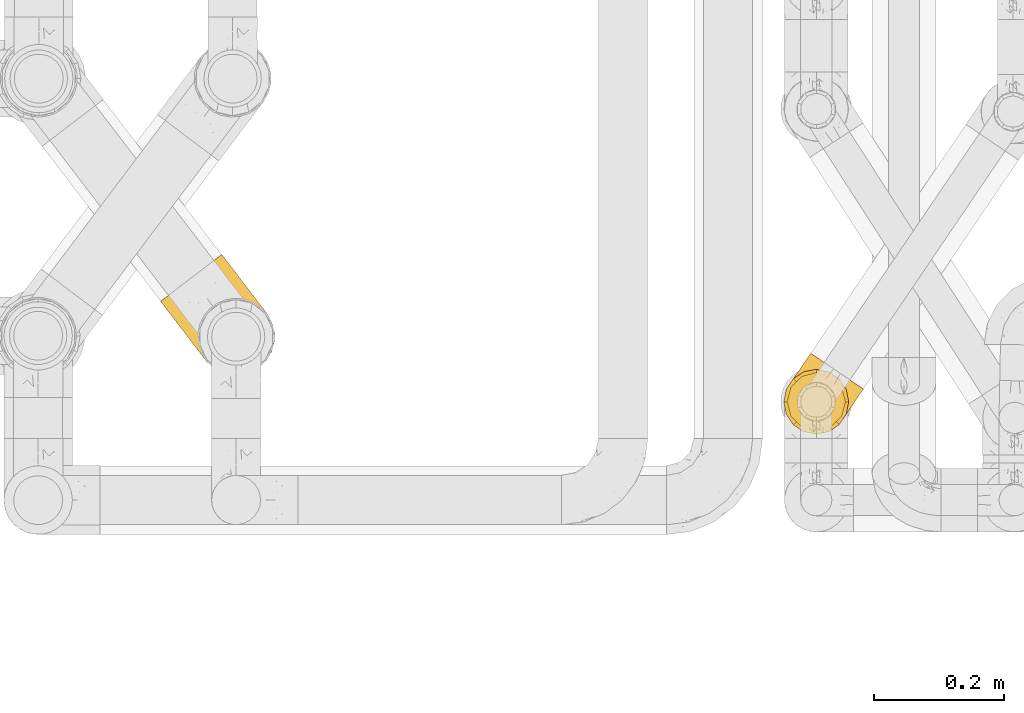
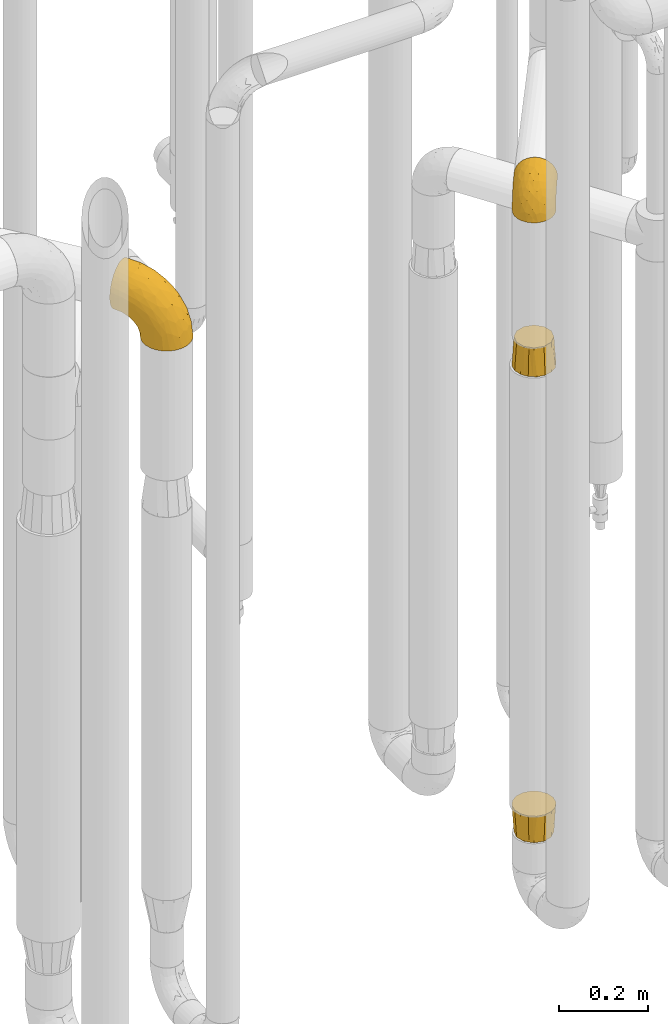
# One storey, part 382 of 827: 4 coverings.
"""IFC2X3 building model written with IfcOpenShell, lengths in millimetres."""

from ifc_helpers import new_model, entity, si_unit, converted_unit, derived_unit, direction, frame, origin, place, context, subcontext, project, spatial, faceted_brep, element, save


model = new_model("IFC2X3")

# Units and contexts
model_context = context("Model", 3, precision=0.01, world=origin(), true_north=direction((6.12303176911189e-17, 1.0)))
body_context = subcontext(model_context, "Body", "Model", "MODEL_VIEW")
ifc_project = project(units=[si_unit("LENGTHUNIT", "METRE", prefix="MILLI"), si_unit("AREAUNIT", "SQUARE_METRE"), si_unit("VOLUMEUNIT", "CUBIC_METRE"), converted_unit("PLANEANGLEUNIT", "DEGREE", entity("IfcRatioMeasure", 0.0174532925199433), si_unit("PLANEANGLEUNIT", "RADIAN"), dimensions=[0, 0, 0, 0, 0, 0, 0]), si_unit("MASSUNIT", "GRAM", prefix="KILO"), derived_unit("MASSDENSITYUNIT", [(si_unit("MASSUNIT", "GRAM", prefix="KILO"), 1), (si_unit("LENGTHUNIT", "METRE"), -3)]), derived_unit("MOMENTOFINERTIAUNIT", [(si_unit("LENGTHUNIT", "METRE"), 4)]), si_unit("TIMEUNIT", "SECOND"), si_unit("FREQUENCYUNIT", "HERTZ"), si_unit("THERMODYNAMICTEMPERATUREUNIT", "DEGREE_CELSIUS"), derived_unit("THERMALTRANSMITTANCEUNIT", [(si_unit("MASSUNIT", "GRAM", prefix="KILO"), 1), (si_unit("THERMODYNAMICTEMPERATUREUNIT", "KELVIN"), -1), (si_unit("TIMEUNIT", "SECOND"), -3)]), derived_unit("VOLUMETRICFLOWRATEUNIT", [(si_unit("LENGTHUNIT", "METRE"), 3), (si_unit("TIMEUNIT", "SECOND"), -1)]), derived_unit("MASSFLOWRATEUNIT", [(si_unit("MASSUNIT", "GRAM", prefix="KILO"), 1), (si_unit("TIMEUNIT", "SECOND"), -1)]), derived_unit("ROTATIONALFREQUENCYUNIT", [(si_unit("TIMEUNIT", "SECOND"), -1)]), si_unit("ELECTRICCURRENTUNIT", "AMPERE"), si_unit("ELECTRICVOLTAGEUNIT", "VOLT"), si_unit("POWERUNIT", "WATT"), si_unit("FORCEUNIT", "NEWTON", prefix="KILO"), si_unit("ILLUMINANCEUNIT", "LUX"), si_unit("LUMINOUSFLUXUNIT", "LUMEN"), si_unit("LUMINOUSINTENSITYUNIT", "CANDELA"), derived_unit("USERDEFINED", [(si_unit("MASSUNIT", "GRAM", prefix="KILO"), -1), (si_unit("LENGTHUNIT", "METRE"), -2), (si_unit("TIMEUNIT", "SECOND"), 3), (si_unit("LUMINOUSFLUXUNIT", "LUMEN"), 1)]), derived_unit("LINEARVELOCITYUNIT", [(si_unit("LENGTHUNIT", "METRE"), 1), (si_unit("TIMEUNIT", "SECOND"), -1)]), si_unit("PRESSUREUNIT", "PASCAL"), derived_unit("USERDEFINED", [(si_unit("LENGTHUNIT", "METRE"), -2), (si_unit("MASSUNIT", "GRAM", prefix="KILO"), 1), (si_unit("TIMEUNIT", "SECOND"), -2)]), derived_unit("LINEARFORCEUNIT", [(si_unit("MASSUNIT", "GRAM", prefix="KILO"), 1), (si_unit("LENGTHUNIT", "METRE"), 1), (si_unit("TIMEUNIT", "SECOND"), -2), (si_unit("LENGTHUNIT", "METRE"), -1)]), derived_unit("PLANARFORCEUNIT", [(si_unit("MASSUNIT", "GRAM", prefix="KILO"), 1), (si_unit("LENGTHUNIT", "METRE"), 1), (si_unit("TIMEUNIT", "SECOND"), -2), (si_unit("LENGTHUNIT", "METRE"), -2)])], contexts=[model_context])

# Site, building, storey
site_placement = place(None, origin())
site = spatial("IfcSite", under=ifc_project, at=site_placement, CompositionType="ELEMENT")
building_placement = place(site_placement, origin())
building = spatial("IfcBuilding", under=site, at=building_placement, CompositionType="ELEMENT")
storey_placement = place(building_placement, frame((0.0, 0.0, 28200.0)))
storey = spatial("IfcBuildingStorey", under=building, at=storey_placement, Name="08", CompositionType="ELEMENT", Elevation=28200.0)

# Coverings
covering_1_placement = place(storey_placement, frame((46642.17, 13737.89, 2241.4)))
element("IfcCovering", 1, at=covering_1_placement, inside=storey, Name=":ADSK_", ObjectType=":ADSK_", PredefinedType="INSULATION", context=body_context, shape_type="Brep", body=[
    faceted_brep([(41.93, 125.38, 58.6), (42.95, 124.69, 69.54), (45.96, 122.64, 79.93), (50.81, 119.36, 89.25), (57.25, 114.99, 97.03), (64.96, 109.76, 102.88), (73.56, 103.93, 106.51), (82.61, 97.79, 107.75), (91.66, 91.65, 106.51), (100.26, 85.82, 102.87), (107.98, 80.59, 97.02), (114.42, 76.22, 89.23), (119.26, 72.94, 79.91), (122.27, 70.9, 69.53), (123.29, 70.21, 58.6), (122.76, 70.57, 52.89), (122.27, 70.9, 47.65), (120.76, 71.92, 42.46), (119.26, 72.94, 37.26), (114.41, 76.23, 27.94), (107.97, 80.6, 20.16), (100.25, 85.83, 14.31), (91.66, 91.66, 10.68), (82.61, 97.79, 9.45), (73.55, 103.93, 10.68), (64.95, 109.77, 14.32), (57.24, 115.0, 20.17), (50.8, 119.36, 27.96), (45.96, 122.65, 37.28), (44.45, 123.67, 42.47), (42.95, 124.69, 47.66), (42.46, 125.02, 52.89), (42.2, 125.2, 55.75), (87.79, 82.77, 1.6), (94.85, 72.05, 1.6), (96.87, 65.96, 1.6), (98.89, 59.87, 1.6), (99.26, 53.47, 1.6), (99.64, 47.07, 1.6), (98.34, 40.78, 1.6), (97.05, 34.5, 1.6), (93.89, 28.2, 1.6), (92.59, 25.62, 1.6), (91.3, 23.03, 1.6), (82.77, 13.44, 1.6), (72.05, 6.39, 1.6), (59.87, 2.35, 1.6), (47.07, 1.6, 1.6), (34.5, 4.18, 1.6), (23.03, 9.94, 1.6), (13.44, 18.46, 1.6), (6.39, 29.18, 1.6), (2.35, 41.36, 1.6), (1.6, 54.17, 1.6), (4.18, 66.73, 1.6), (9.94, 78.2, 1.6), (13.78, 82.53, 1.6), (18.46, 87.79, 1.6), (23.82, 91.32, 1.6), (29.18, 94.85, 1.6), (35.27, 96.87, 1.6), (41.36, 98.89, 1.6), (47.76, 99.26, 1.6), (54.17, 99.64, 1.6), (66.73, 97.05, 1.6), (78.2, 91.3, 1.6), (30.5, 36.2, 69.96), (17.86, 42.1, 59.59), (20.54, 29.38, 51.96), (25.95, 14.24, 34.4), (18.13, 16.78, 23.37), (24.11, 11.52, 13.68), (10.43, 37.66, 41.52), (12.38, 24.41, 26.26), (5.7, 34.59, 20.18), (25.87, 91.74, 72.33), (31.32, 107.71, 65.88), (20.47, 91.06, 57.55), (3.63, 59.41, 23.76), (8.57, 58.4, 46.5), (10.92, 73.29, 46.57), (6.66, 71.39, 21.17), (12.37, 81.79, 23.41), (11.76, 80.89, 17.92), (11.15, 79.99, 12.43), (10.85, 79.54, 9.72), (10.54, 79.09, 7.01), (3.94, 46.94, 26.77), (35.48, 108.23, 76.59), (48.04, 64.08, 95.55), (56.72, 85.45, 102.57), (40.19, 74.66, 92.89), (29.69, 107.32, 54.26), (27.09, 103.5, 51.17), (24.5, 99.67, 48.08), (21.9, 95.85, 44.99), (19.31, 92.02, 41.9), (38.92, 104.45, 85.16), (37.68, 53.63, 85.97), (14.53, 70.72, 59.58), (52.03, 96.36, 99.5), (75.82, 87.79, 105.83), (12.11, 49.85, 53.59), (17.74, 63.32, 67.0), (21.95, 54.99, 71.56), (47.59, 46.15, 87.47), (41.0, 36.43, 75.73), (41.77, 95.07, 92.24), (40.41, 123.14, 58.06), (38.89, 120.89, 57.52), (35.85, 116.41, 56.44), (32.77, 111.87, 55.35), (29.01, 83.6, 81.33), (27.03, 69.47, 80.35), (12.58, 80.79, 39.44), (64.2, 70.64, 102.55), (17.57, 89.46, 37.28), (15.84, 86.91, 32.65), (14.11, 84.35, 28.03), (34.41, 26.72, 63.99), (27.71, 46.88, 74.55), (31.55, 60.81, 83.62), (55.89, 58.4, 95.01), (30.18, 20.48, 49.19), (38.06, 117.52, 46.96), (16.17, 85.83, 8.77), (18.39, 88.7, 18.28), (18.9, 88.57, 11.68), (65.34, 103.97, 11.79), (57.63, 107.42, 15.69), (31.83, 108.07, 42.49), (32.12, 109.84, 47.41), (44.55, 100.15, 7.94), (36.19, 98.33, 9.27), (54.47, 100.88, 7.98), (44.21, 101.95, 13.4), (56.56, 104.18, 13.04), (66.49, 99.01, 7.36), (39.11, 105.08, 23.46), (35.33, 106.25, 30.46), (42.78, 109.65, 26.54), (33.09, 96.82, 6.76), (47.58, 113.66, 26.46), (50.32, 109.62, 20.77), (35.75, 101.75, 20.68), (38.67, 115.17, 40.26), (79.49, 93.2, 7.15), (73.71, 99.33, 9.28), (29.11, 103.76, 38.78), (48.24, 106.21, 18.27), (27.57, 99.98, 31.78), (25.85, 93.92, 12.75), (19.7, 90.57, 22.96), (27.56, 95.92, 17.55), (23.82, 95.37, 27.63), (35.65, 99.66, 15.23), (42.46, 114.78, 33.25), (38.68, 110.38, 32.43), (19.91, 91.5, 27.9), (95.88, 72.8, 7.97), (101.71, 54.86, 15.22), (98.88, 63.3, 7.93), (100.67, 63.66, 13.38), (97.1, 82.98, 13.12), (110.94, 54.41, 42.49), (112.49, 55.35, 47.4), (108.45, 48.33, 51.17), (115.01, 63.41, 40.24), (105.53, 72.18, 20.76), (91.6, 23.48, 4.31), (92.51, 24.82, 12.43), (91.9, 23.92, 7.01), (110.3, 71.13, 26.44), (108.35, 65.17, 26.52), (97.61, 35.2, 11.68), (100.01, 43.63, 12.75), (100.29, 54.86, 9.27), (101.24, 45.96, 17.55), (100.02, 51.42, 6.76), (113.23, 66.8, 33.21), (110.55, 61.65, 32.41), (96.07, 31.64, 8.77), (99.17, 36.67, 22.96), (97.85, 34.56, 18.48), (117.2, 61.24, 56.44), (117.42, 63.7, 46.95), (89.71, 83.25, 7.36), (93.12, 25.72, 17.92), (93.73, 26.62, 23.41), (90.18, 87.28, 9.85), (120.25, 65.72, 57.52), (118.72, 63.48, 56.98), (105.85, 44.5, 48.08), (107.95, 50.3, 38.78), (103.14, 68.98, 18.25), (103.26, 40.67, 44.99), (105.0, 47.49, 31.74), (107.95, 56.99, 30.45), (102.11, 42.28, 27.63), (103.62, 55.75, 20.65), (114.12, 56.69, 55.35), (111.04, 52.15, 54.26), (98.17, 75.97, 13.03), (105.46, 60.09, 23.44), (99.96, 37.22, 27.9), (97.2, 31.74, 32.65), (95.46, 29.18, 28.03), (98.93, 34.29, 37.28), (100.67, 36.85, 41.9), (92.5, 26.24, 39.74), (31.2, 7.92, 23.37), (64.47, 5.89, 26.77), (73.33, 14.29, 46.18), (64.18, 14.54, 53.54), (53.45, 8.49, 41.53), (54.89, 17.05, 59.61), (109.82, 58.11, 76.79), (110.64, 53.68, 66.11), (86.18, 17.46, 21.17), (42.01, 14.82, 51.96), (40.42, 5.4, 26.26), (52.34, 2.96, 20.18), (76.17, 10.22, 23.76), (76.82, 49.82, 92.88), (80.72, 69.17, 102.57), (64.08, 53.2, 95.54), (65.34, 25.66, 71.63), (55.62, 27.95, 74.55), (98.4, 43.34, 72.51), (44.67, 26.59, 69.96), (95.2, 58.84, 92.23), (104.97, 59.66, 85.15), (76.86, 35.77, 80.45), (67.12, 36.7, 83.65), (99.33, 37.56, 57.57), (85.9, 28.59, 63.68), (58.15, 39.71, 85.95), (92.6, 68.84, 99.49), (89.17, 42.61, 81.23), (85.85, 21.87, 47.07), (74.6, 24.78, 66.99)], [[[0, 1, 2, 3, 4, 5, 6, 7, 8, 9, 10, 11, 12, 13, 14, 15, 16, 17, 18, 19, 20, 21, 22, 23, 24, 25, 26, 27, 28, 29, 30, 31, 32]], [[33, 34, 35, 36, 37, 38, 39, 40, 41, 42, 43, 44, 45, 46, 47, 48, 49, 50, 51, 52, 53, 54, 55, 56, 57, 58, 59, 60, 61, 62, 63, 64, 65]], [[66, 67, 68]], [[69, 70, 71]], [[68, 72, 73]], [[73, 72, 74]], [[75, 76, 77]], [[78, 79, 80]], [[51, 50, 73]], [[81, 82, 83, 84, 85, 86, 55]], [[52, 87, 53]], [[74, 52, 51]], [[2, 1, 88]], [[89, 90, 91]], [[77, 92, 93, 94, 95, 96]], [[55, 54, 81]], [[78, 53, 87]], [[5, 90, 6]], [[88, 76, 75]], [[97, 3, 2]], [[89, 91, 98]], [[99, 80, 79]], [[90, 5, 100]], [[74, 87, 52]], [[100, 5, 4]], [[90, 101, 6]], [[79, 102, 103]], [[102, 67, 104]], [[105, 98, 106]], [[107, 4, 3]], [[76, 0, 108, 109, 110, 111, 92]], [[107, 112, 113]], [[114, 77, 96]], [[89, 115, 90]], [[114, 96, 116, 117, 118, 82]], [[75, 97, 88]], [[119, 66, 68]], [[50, 71, 70]], [[100, 91, 90]], [[99, 77, 80]], [[102, 104, 103]], [[97, 107, 3]], [[80, 81, 78]], [[107, 97, 112]], [[68, 73, 70]], [[66, 98, 120]], [[78, 81, 54]], [[114, 81, 80]], [[53, 78, 54]], [[78, 87, 79]], [[102, 87, 72]], [[79, 103, 99]], [[4, 107, 100]], [[91, 100, 107]], [[88, 97, 2]], [[112, 97, 75]], [[99, 112, 75]], [[103, 104, 113]], [[91, 121, 98]], [[89, 105, 122, 115]], [[101, 90, 115]], [[101, 7, 6]], [[88, 1, 76]], [[0, 76, 1]], [[92, 77, 76]], [[73, 74, 51]], [[87, 74, 72]], [[81, 114, 82]], [[77, 114, 80]], [[87, 102, 79]], [[67, 102, 72]], [[68, 67, 72]], [[67, 120, 104]], [[120, 121, 104]], [[104, 121, 113]], [[121, 120, 98]], [[91, 107, 113]], [[91, 113, 121]], [[103, 113, 112]], [[106, 98, 66]], [[105, 89, 98]], [[106, 66, 119]], [[67, 66, 120]], [[68, 69, 123, 119]], [[50, 49, 71]], [[50, 70, 73]], [[112, 99, 103]], [[77, 99, 75]], [[69, 68, 70]], [[29, 124, 110]], [[84, 83, 125]], [[126, 82, 118]], [[59, 58, 127]], [[25, 128, 129]], [[130, 93, 131]], [[132, 62, 133]], [[134, 135, 136]], [[137, 65, 64]], [[64, 134, 137]], [[138, 139, 140]], [[111, 110, 124, 92]], [[134, 136, 137]], [[134, 64, 63]], [[133, 61, 141]], [[125, 58, 57]], [[142, 143, 140]], [[142, 26, 143]], [[127, 83, 82]], [[28, 124, 29]], [[108, 0, 32, 31, 30, 110, 109]], [[30, 29, 110]], [[135, 144, 138]], [[28, 145, 124]], [[57, 56, 55, 86, 85, 84]], [[146, 147, 23]], [[24, 23, 147]], [[25, 143, 26]], [[95, 94, 148]], [[24, 128, 25]], [[149, 138, 143]], [[124, 145, 131]], [[127, 58, 125]], [[150, 148, 139]], [[127, 126, 151]], [[151, 59, 127]], [[152, 151, 126]], [[153, 154, 155]], [[153, 133, 141]], [[145, 28, 27]], [[142, 156, 27]], [[157, 148, 130]], [[61, 133, 62]], [[134, 132, 135]], [[147, 128, 24]], [[65, 137, 146]], [[146, 137, 147]], [[128, 137, 136]], [[137, 128, 147]], [[128, 136, 129]], [[149, 129, 136]], [[25, 129, 143]], [[158, 152, 117]], [[152, 118, 117]], [[153, 151, 152]], [[158, 116, 154]], [[144, 150, 138]], [[153, 152, 158]], [[133, 153, 155]], [[133, 155, 132]], [[141, 61, 60]], [[135, 132, 155]], [[134, 63, 132]], [[144, 135, 155]], [[135, 138, 149]], [[155, 154, 144]], [[150, 154, 96]], [[154, 150, 144]], [[148, 94, 130]], [[82, 126, 127]], [[118, 152, 126]], [[150, 96, 95]], [[139, 148, 157]], [[150, 95, 148]], [[93, 92, 131]], [[130, 145, 156]], [[130, 94, 93]], [[84, 125, 57]], [[127, 125, 83]], [[140, 139, 157]], [[150, 139, 138]], [[140, 157, 142]], [[138, 140, 143]], [[156, 142, 157]], [[27, 26, 142]], [[130, 156, 157]], [[145, 27, 156]], [[132, 63, 62]], [[124, 131, 92]], [[130, 131, 145]], [[129, 149, 143]], [[135, 149, 136]], [[60, 151, 141]], [[59, 151, 60]], [[141, 151, 153]], [[116, 96, 154]], [[153, 158, 154]], [[158, 117, 116]], [[34, 33, 159]], [[160, 161, 162]], [[22, 21, 163]], [[164, 165, 166]], [[19, 18, 167]], [[168, 21, 20]], [[169, 43, 42, 41, 40, 170, 171]], [[172, 173, 168]], [[174, 38, 175]], [[176, 177, 178]], [[179, 164, 180]], [[40, 181, 170]], [[182, 183, 175]], [[17, 184, 185]], [[65, 146, 186]], [[187, 174, 188]], [[23, 22, 189]], [[174, 39, 38]], [[15, 14, 190, 191, 184, 16]], [[181, 40, 39]], [[192, 193, 164]], [[194, 163, 168]], [[33, 186, 159]], [[180, 173, 172]], [[195, 196, 193]], [[18, 185, 167]], [[173, 180, 197]], [[198, 199, 196]], [[200, 201, 185, 184]], [[184, 17, 16]], [[18, 17, 185]], [[202, 159, 186]], [[194, 168, 203]], [[189, 163, 202]], [[204, 205, 182]], [[187, 181, 174]], [[160, 177, 176]], [[206, 183, 182]], [[206, 182, 205]], [[201, 165, 185]], [[165, 164, 167]], [[172, 179, 180]], [[202, 194, 162]], [[176, 161, 160]], [[65, 186, 33]], [[163, 189, 22]], [[175, 177, 182]], [[174, 183, 188]], [[177, 198, 204]], [[199, 160, 162]], [[198, 207, 204]], [[175, 38, 37]], [[198, 177, 160]], [[178, 177, 175]], [[176, 35, 161]], [[34, 159, 161]], [[162, 161, 159]], [[202, 162, 159]], [[199, 162, 203]], [[196, 199, 203]], [[198, 160, 199]], [[193, 197, 180]], [[208, 198, 196]], [[188, 183, 206]], [[175, 183, 174]], [[193, 192, 195]], [[195, 208, 196]], [[197, 196, 203]], [[180, 164, 193]], [[168, 163, 21]], [[166, 165, 201]], [[166, 192, 164]], [[189, 202, 186]], [[186, 146, 189]], [[23, 189, 146]], [[174, 181, 39]], [[170, 181, 187]], [[196, 197, 193]], [[173, 203, 168]], [[203, 173, 197]], [[172, 168, 20]], [[20, 19, 172]], [[179, 172, 19]], [[19, 167, 179]], [[164, 179, 167]], [[35, 176, 36]], [[35, 34, 161]], [[185, 165, 167]], [[162, 194, 203]], [[163, 194, 202]], [[176, 178, 36]], [[37, 36, 178]], [[175, 37, 178]], [[177, 204, 182]], [[207, 198, 208]], [[207, 205, 204]], [[209, 188, 206, 205, 207, 208]], [[48, 210, 71]], [[211, 212, 213]], [[214, 213, 215]], [[216, 217, 13]], [[218, 43, 169, 171, 170, 187, 188]], [[219, 220, 214]], [[47, 46, 221]], [[210, 48, 220]], [[211, 222, 212]], [[222, 45, 44]], [[221, 220, 47]], [[47, 220, 48]], [[221, 211, 214]], [[223, 224, 225]], [[211, 46, 45]], [[226, 227, 215]], [[43, 218, 44]], [[217, 216, 228]], [[219, 215, 229]], [[14, 13, 217]], [[224, 9, 8]], [[10, 230, 11]], [[11, 231, 12]], [[232, 223, 233]], [[234, 208, 195, 192, 166, 201]], [[235, 234, 228]], [[222, 44, 218]], [[106, 229, 236]], [[224, 237, 9]], [[231, 238, 228]], [[9, 237, 10]], [[115, 224, 101]], [[239, 234, 235]], [[231, 11, 230]], [[223, 230, 237]], [[224, 8, 101]], [[223, 236, 233]], [[225, 115, 122, 105]], [[216, 12, 231]], [[209, 234, 239]], [[210, 219, 69]], [[219, 214, 215]], [[229, 119, 219]], [[209, 218, 188]], [[239, 212, 222]], [[239, 222, 218]], [[45, 222, 211]], [[235, 212, 239]], [[213, 212, 240]], [[223, 237, 224]], [[230, 10, 237]], [[238, 231, 230]], [[216, 231, 228]], [[232, 230, 223]], [[235, 238, 240]], [[115, 225, 224]], [[233, 236, 227]], [[8, 7, 101]], [[234, 209, 208]], [[218, 209, 239]], [[217, 228, 234]], [[13, 12, 216]], [[234, 201, 217]], [[217, 201, 200, 184, 191, 190, 14]], [[211, 221, 46]], [[220, 221, 214]], [[71, 210, 69]], [[71, 49, 48]], [[219, 210, 220]], [[226, 215, 213]], [[211, 213, 214]], [[226, 213, 240]], [[215, 227, 229]], [[232, 240, 238]], [[233, 227, 226]], [[232, 233, 226]], [[236, 223, 225]], [[240, 232, 226]], [[232, 238, 230]], [[225, 105, 236]], [[236, 105, 106]], [[236, 229, 227]], [[123, 69, 219, 119]], [[106, 119, 229]], [[238, 235, 228]], [[212, 235, 240]]]),
])
covering_2_placement = place(storey_placement, frame((46641.19, 13736.91, 541.02)))
element("IfcCovering", 2, at=covering_2_placement, inside=storey, Name=":ADSK_", ObjectType=":ADSK_", PredefinedType="INSULATION", context=body_context, shape_type="Brep", body=[
    faceted_brep([(70.73, 97.79, 76.0), (61.16, 99.69, 76.0), (51.6, 101.6, 76.0), (42.03, 99.69, 76.0), (32.46, 97.79, 76.0), (24.35, 92.37, 76.0), (16.24, 86.95, 76.0), (10.82, 78.84, 76.0), (5.4, 70.73, 76.0), (3.5, 61.16, 76.0), (1.6, 51.6, 76.0), (3.5, 42.03, 76.0), (5.4, 32.46, 76.0), (10.82, 24.35, 76.0), (16.24, 16.24, 76.0), (24.35, 10.82, 76.0), (32.46, 5.4, 76.0), (42.03, 3.5, 76.0), (51.6, 1.6, 76.0), (61.16, 3.5, 76.0), (70.73, 5.4, 76.0), (78.84, 10.82, 76.0), (86.95, 16.24, 76.0), (92.37, 24.35, 76.0), (97.79, 32.46, 76.0), (99.69, 42.03, 76.0), (101.6, 51.6, 76.0), (99.69, 61.16, 76.0), (97.79, 70.73, 76.0), (92.37, 78.84, 76.0), (86.95, 86.95, 76.0), (78.84, 92.37, 76.0), (12.62, 74.1, 0.0), (20.86, 82.33, 0.0), (29.1, 90.57, 0.0), (40.35, 93.58, 0.0), (51.6, 96.6, 0.0), (62.85, 93.58, 0.0), (74.1, 90.57, 0.0), (82.33, 82.33, 0.0), (90.57, 74.1, 0.0), (93.58, 62.85, 0.0), (96.6, 51.6, 0.0), (93.58, 40.35, 0.0), (90.57, 29.1, 0.0), (82.33, 20.86, 0.0), (74.1, 12.62, 0.0), (62.85, 9.61, 0.0), (51.6, 6.6, 0.0), (40.35, 9.61, 0.0), (29.1, 12.62, 0.0), (20.86, 20.86, 0.0), (12.62, 29.1, 0.0), (9.61, 40.35, 0.0), (6.6, 51.6, 0.0), (9.61, 62.85, 0.0)], [[[0, 1, 2, 3, 4, 5, 6, 7, 8, 9, 10, 11, 12, 13, 14, 15, 16, 17, 18, 19, 20, 21, 22, 23, 24, 25, 26, 27, 28, 29, 30, 31]], [[32, 33, 34, 35, 36, 37, 38, 39, 40, 41, 42, 43, 44, 45, 46, 47, 48, 49, 50, 51, 52, 53, 54, 55]], [[11, 10, 54]], [[50, 15, 51]], [[51, 13, 52]], [[54, 53, 11]], [[14, 51, 15]], [[17, 48, 18]], [[13, 12, 52]], [[13, 51, 14]], [[48, 17, 49]], [[53, 52, 12]], [[53, 12, 11]], [[16, 50, 49]], [[17, 16, 49]], [[50, 16, 15]], [[19, 18, 48]], [[44, 23, 45]], [[45, 21, 46]], [[48, 47, 19]], [[22, 45, 23]], [[25, 42, 26]], [[21, 20, 46]], [[21, 45, 22]], [[42, 25, 43]], [[47, 46, 20]], [[47, 20, 19]], [[24, 44, 43]], [[25, 24, 43]], [[44, 24, 23]], [[27, 26, 42]], [[38, 31, 39]], [[39, 29, 40]], [[42, 41, 27]], [[30, 39, 31]], [[1, 36, 2]], [[29, 28, 40]], [[29, 39, 30]], [[36, 1, 37]], [[41, 40, 28]], [[41, 28, 27]], [[0, 38, 37]], [[1, 0, 37]], [[38, 0, 31]], [[3, 2, 36]], [[32, 7, 33]], [[33, 5, 34]], [[36, 35, 3]], [[6, 33, 7]], [[9, 54, 10]], [[5, 4, 34]], [[5, 33, 6]], [[54, 9, 55]], [[35, 34, 4]], [[35, 4, 3]], [[8, 32, 55]], [[9, 8, 55]], [[32, 8, 7]]]),
])
covering_3_placement = place(storey_placement, frame((46641.19, 13736.91, 1821.5)))
element("IfcCovering", 3, at=covering_3_placement, inside=storey, Name=":ADSK_", ObjectType=":ADSK_", PredefinedType="INSULATION", context=body_context, shape_type="Brep", body=[
    faceted_brep([(62.85, 93.58, 76.0), (51.6, 96.6, 76.0), (40.35, 93.58, 76.0), (29.1, 90.57, 76.0), (20.86, 82.33, 76.0), (12.62, 74.1, 76.0), (9.61, 62.85, 76.0), (6.6, 51.6, 76.0), (9.61, 40.35, 76.0), (12.62, 29.1, 76.0), (20.86, 20.86, 76.0), (29.1, 12.62, 76.0), (40.35, 9.61, 76.0), (51.6, 6.6, 76.0), (62.85, 9.61, 76.0), (74.1, 12.62, 76.0), (82.33, 20.86, 76.0), (90.57, 29.1, 76.0), (93.58, 40.35, 76.0), (96.6, 51.6, 76.0), (93.58, 62.85, 76.0), (90.57, 74.1, 76.0), (82.33, 82.33, 76.0), (74.1, 90.57, 76.0), (97.79, 32.46, 0.0), (92.37, 24.35, 0.0), (86.95, 16.24, 0.0), (78.84, 10.82, 0.0), (70.73, 5.4, 0.0), (61.16, 3.5, 0.0), (51.6, 1.6, 0.0), (42.03, 3.5, 0.0), (32.46, 5.4, 0.0), (24.35, 10.82, 0.0), (16.24, 16.24, 0.0), (10.82, 24.35, 0.0), (5.4, 32.46, 0.0), (3.5, 42.03, 0.0), (1.6, 51.6, 0.0), (3.5, 61.16, 0.0), (5.4, 70.73, 0.0), (10.82, 78.84, 0.0), (16.24, 86.95, 0.0), (24.35, 92.37, 0.0), (32.46, 97.79, 0.0), (42.03, 99.69, 0.0), (51.6, 101.6, 0.0), (61.16, 99.69, 0.0), (70.73, 97.79, 0.0), (78.84, 92.37, 0.0), (86.95, 86.95, 0.0), (92.37, 78.84, 0.0), (97.79, 70.73, 0.0), (99.69, 61.16, 0.0), (101.6, 51.6, 0.0), (99.69, 42.03, 0.0)], [[[0, 1, 2, 3, 4, 5, 6, 7, 8, 9, 10, 11, 12, 13, 14, 15, 16, 17, 18, 19, 20, 21, 22, 23]], [[24, 25, 26, 27, 28, 29, 30, 31, 32, 33, 34, 35, 36, 37, 38, 39, 40, 41, 42, 43, 44, 45, 46, 47, 48, 49, 50, 51, 52, 53, 54, 55]], [[39, 38, 7]], [[41, 40, 5]], [[41, 5, 4]], [[3, 43, 4]], [[41, 4, 42]], [[45, 1, 46]], [[7, 6, 39]], [[43, 42, 4]], [[1, 45, 2]], [[6, 5, 40]], [[6, 40, 39]], [[44, 3, 2]], [[45, 44, 2]], [[3, 44, 43]], [[31, 30, 13]], [[33, 32, 11]], [[33, 11, 10]], [[9, 35, 10]], [[33, 10, 34]], [[37, 7, 38]], [[13, 12, 31]], [[35, 34, 10]], [[7, 37, 8]], [[12, 11, 32]], [[12, 32, 31]], [[36, 9, 8]], [[37, 36, 8]], [[9, 36, 35]], [[55, 54, 19]], [[25, 24, 17]], [[25, 17, 16]], [[15, 27, 16]], [[25, 16, 26]], [[29, 13, 30]], [[19, 18, 55]], [[27, 26, 16]], [[13, 29, 14]], [[18, 17, 24]], [[18, 24, 55]], [[28, 15, 14]], [[29, 28, 14]], [[15, 28, 27]], [[47, 46, 1]], [[49, 48, 23]], [[49, 23, 22]], [[21, 51, 22]], [[49, 22, 50]], [[53, 19, 54]], [[1, 0, 47]], [[51, 50, 22]], [[19, 53, 20]], [[0, 23, 48]], [[0, 48, 47]], [[52, 21, 20]], [[53, 52, 20]], [[21, 52, 51]]]),
])
covering_4_placement = place(storey_placement, frame((45680.37, 13828.27, 2149.4)))
element("IfcCovering", 4, at=covering_4_placement, inside=storey, Name=":ADSK_", ObjectType=":ADSK_", PredefinedType="INSULATION", context=body_context, shape_type="Brep", body=[
    faceted_brep([(1.6, 114.99, 115.6), (2.78, 115.9, 128.83), (6.27, 118.57, 141.39), (11.9, 122.87, 152.67), (19.38, 128.59, 162.08), (28.34, 135.44, 169.16), (38.32, 143.07, 173.56), (48.82, 151.1, 175.05), (59.33, 159.14, 173.55), (69.31, 166.78, 169.16), (78.27, 173.62, 162.07), (85.74, 179.34, 152.66), (91.37, 183.64, 141.38), (94.86, 186.31, 128.81), (96.04, 187.22, 115.6), (94.86, 186.31, 102.36), (91.36, 183.64, 89.8), (85.74, 179.34, 78.52), (78.26, 173.62, 69.11), (69.3, 166.77, 62.03), (59.32, 159.13, 57.63), (48.82, 151.1, 56.15), (38.31, 143.07, 57.64), (28.33, 135.43, 62.03), (19.37, 128.58, 69.12), (11.89, 122.87, 78.54), (6.27, 118.56, 89.81), (2.78, 115.89, 102.38), (95.41, 115.51, 1.6), (110.41, 119.5, 1.6), (125.93, 119.48, 1.6), (140.91, 115.44, 1.6), (154.34, 107.66, 1.6), (165.29, 96.66, 1.6), (173.03, 83.21, 1.6), (177.02, 68.21, 1.6), (177.0, 52.69, 1.6), (172.96, 37.71, 1.6), (165.18, 24.28, 1.6), (154.18, 13.33, 1.6), (140.73, 5.59, 1.6), (125.73, 1.6, 1.6), (110.22, 1.62, 1.6), (95.23, 5.66, 1.6), (81.8, 13.44, 1.6), (70.85, 24.44, 1.6), (63.11, 37.89, 1.6), (59.12, 52.89, 1.6), (59.14, 68.4, 1.6), (63.18, 83.39, 1.6), (70.96, 96.82, 1.6), (81.96, 107.77, 1.6), (118.05, 3.46, 32.35), (131.89, 7.7, 43.24), (113.59, 12.35, 67.79), (142.54, 10.84, 39.06), (150.59, 18.02, 46.49), (38.65, 85.23, 143.21), (59.62, 58.62, 128.0), (58.66, 72.95, 144.51), (116.12, 32.0, 104.87), (140.07, 31.78, 88.32), (123.32, 53.68, 124.24), (77.53, 23.59, 70.72), (89.72, 12.23, 48.42), (86.8, 19.7, 74.22), (80.32, 16.28, 37.66), (68.98, 28.56, 61.68), (70.12, 76.89, 151.61), (48.91, 101.67, 162.2), (124.45, 16.07, 73.52), (137.29, 17.81, 66.93), (102.27, 7.03, 43.54), (76.09, 115.44, 169.14), (59.91, 106.77, 166.98), (99.89, 59.17, 137.86), (83.77, 84.41, 156.83), (68.68, 39.62, 103.08), (80.96, 37.89, 111.05), (20.67, 91.75, 122.98), (38.91, 67.88, 111.19), (47.39, 63.0, 120.32), (57.62, 41.73, 68.6), (62.54, 35.3, 52.71), (67.46, 28.87, 36.82), (101.5, 82.21, 151.81), (25.24, 91.51, 134.29), (36.59, 100.62, 155.8), (100.72, 28.75, 102.22), (82.93, 51.3, 130.43), (95.78, 18.87, 80.3), (58.39, 43.8, 92.65), (42.3, 61.76, 93.82), (49.96, 51.75, 81.21), (10.48, 103.38, 113.28), (23.0, 87.01, 110.02), (32.65, 74.39, 101.92), (69.44, 26.27, 16.21), (32.94, 78.64, 84.67), (19.76, 100.31, 87.66), (29.88, 96.63, 74.04), (61.62, 40.19, 21.09), (58.68, 44.67, 35.03), (47.89, 69.76, 52.93), (52.47, 76.59, 39.76), (54.1, 65.96, 34.91), (39.89, 77.65, 67.69), (59.56, 113.02, 44.31), (52.86, 98.18, 44.87), (46.7, 113.59, 54.18), (61.5, 134.52, 51.99), (51.55, 126.43, 53.35), (57.81, 56.68, 18.29), (57.33, 73.08, 23.44), (60.22, 90.61, 28.92), (64.71, 89.25, 13.79), (70.68, 100.33, 18.1), (68.84, 108.67, 32.62), (79.43, 111.07, 22.47), (13.56, 101.88, 100.59), (42.5, 63.95, 78.3), (48.74, 58.0, 62.67), (39.6, 127.13, 58.76), (32.67, 113.51, 64.93), (43.55, 100.03, 56.12), (21.96, 112.21, 75.28), (23.85, 87.93, 97.34), (38.29, 91.59, 64.0), (72.25, 120.46, 40.17), (54.86, 55.34, 38.41), (56.21, 45.81, 51.71), (46.21, 85.54, 52.67), (119.75, 128.07, 39.74), (112.76, 136.44, 52.66), (127.56, 130.69, 52.9), (146.29, 114.58, 27.75), (148.5, 116.39, 51.71), (153.23, 110.59, 38.57), (82.73, 130.77, 44.33), (122.03, 140.48, 67.68), (136.75, 133.99, 93.82), (144.41, 123.97, 81.21), (134.59, 134.37, 78.3), (92.09, 116.7, 18.1), (105.45, 165.84, 87.65), (104.35, 119.56, 13.78), (93.38, 166.84, 75.27), (89.31, 156.84, 64.92), (152.51, 109.7, 21.09), (163.89, 98.5, 16.21), (138.69, 126.79, 62.67), (121.89, 122.45, 23.43), (84.54, 120.68, 32.63), (137.59, 117.69, 18.29), (109.01, 145.67, 63.99), (99.46, 142.83, 56.13), (71.9, 142.01, 53.35), (117.44, 159.24, 110.02), (127.1, 146.61, 101.92), (116.34, 158.65, 97.32), (104.92, 175.61, 113.28), (85.54, 143.33, 54.19), (74.34, 153.73, 58.76), (98.82, 133.34, 44.88), (104.21, 124.25, 28.91), (156.99, 107.53, 52.71), (122.91, 147.43, 84.65), (106.34, 155.1, 74.03), (105.56, 172.23, 100.57), (129.6, 123.71, 34.93), (152.07, 113.96, 68.6), (161.9, 101.1, 36.82), (139.65, 120.19, 38.41), (165.76, 52.25, 67.79), (173.17, 45.62, 32.35), (173.85, 61.78, 43.54), (172.13, 75.25, 48.42), (159.63, 23.91, 39.06), (165.46, 33.37, 43.24), (154.28, 30.8, 66.93), (161.8, 99.54, 61.68), (134.22, 129.4, 120.32), (113.48, 162.71, 122.97), (112.51, 158.25, 134.28), (149.66, 90.43, 111.05), (135.22, 116.5, 128.03), (136.2, 92.06, 130.43), (131.73, 138.87, 111.19), (149.87, 113.76, 92.65), (170.69, 85.38, 37.66), (159.33, 42.74, 73.52), (121.67, 121.14, 144.5), (100.75, 149.69, 155.79), (114.86, 111.13, 151.61), (91.42, 144.75, 164.01), (124.17, 77.73, 137.86), (146.14, 54.95, 104.87), (115.05, 143.69, 143.2), (165.68, 80.03, 74.22), (151.19, 102.74, 103.12), (88.71, 128.8, 166.97), (164.13, 71.13, 80.3), (153.3, 68.96, 102.23), (106.81, 101.68, 155.79), (164.36, 90.0, 70.72)], [[[0, 1, 2, 3, 4, 5, 6, 7, 8, 9, 10, 11, 12, 13, 14, 15, 16, 17, 18, 19, 20, 21, 22, 23, 24, 25, 26, 27]], [[28, 29, 30, 31, 32, 33, 34, 35, 36, 37, 38, 39, 40, 41, 42, 43, 44, 45, 46, 47, 48, 49, 50, 51]], [[52, 53, 54]], [[55, 39, 56]], [[57, 58, 59]], [[60, 61, 62]], [[63, 64, 65]], [[66, 63, 67]], [[59, 68, 69]], [[53, 70, 54]], [[41, 40, 53]], [[53, 71, 70]], [[72, 42, 52]], [[42, 41, 52]], [[73, 6, 74]], [[68, 75, 76]], [[43, 72, 64]], [[45, 44, 66]], [[58, 77, 78]], [[79, 80, 81]], [[67, 82, 83, 84]], [[75, 62, 85]], [[2, 1, 86]], [[3, 87, 4]], [[57, 87, 3]], [[42, 72, 43]], [[6, 5, 74]], [[3, 2, 57]], [[69, 4, 87]], [[6, 73, 7]], [[59, 87, 57]], [[66, 64, 63]], [[88, 89, 78]], [[54, 88, 90]], [[75, 60, 62]], [[91, 92, 93, 82]], [[79, 0, 94, 95]], [[76, 73, 74]], [[80, 95, 96, 92]], [[57, 2, 86]], [[56, 71, 55]], [[77, 91, 63]], [[80, 91, 81]], [[67, 91, 82]], [[71, 56, 61]], [[69, 5, 4]], [[74, 69, 68]], [[75, 89, 60]], [[80, 79, 95]], [[81, 57, 86]], [[76, 75, 85]], [[89, 68, 59]], [[58, 57, 81]], [[59, 58, 89]], [[90, 88, 78]], [[75, 68, 89]], [[70, 88, 54]], [[60, 89, 88]], [[77, 58, 81]], [[89, 58, 78]], [[91, 77, 81]], [[77, 63, 65]], [[78, 77, 65]], [[54, 90, 72]], [[91, 80, 92]], [[79, 81, 86]], [[86, 1, 79]], [[0, 79, 1]], [[66, 84, 97, 45]], [[91, 67, 63]], [[84, 66, 67]], [[64, 44, 43]], [[64, 66, 44]], [[65, 72, 90]], [[53, 52, 41]], [[72, 52, 54]], [[72, 65, 64]], [[65, 90, 78]], [[60, 71, 61]], [[55, 71, 53]], [[71, 60, 70]], [[88, 70, 60]], [[53, 40, 55]], [[39, 55, 40]], [[5, 69, 74]], [[59, 69, 87]], [[73, 76, 85]], [[68, 76, 74]], [[98, 99, 100]], [[84, 101, 97]], [[84, 83, 102]], [[97, 101, 46]], [[103, 104, 105]], [[47, 46, 101]], [[106, 98, 100]], [[107, 108, 109]], [[110, 107, 111]], [[112, 48, 47]], [[48, 113, 49]], [[113, 114, 115]], [[116, 51, 50]], [[115, 50, 49]], [[116, 117, 118]], [[119, 95, 94]], [[111, 107, 109]], [[93, 120, 121]], [[122, 123, 23]], [[121, 106, 103]], [[26, 25, 99]], [[114, 113, 104]], [[124, 109, 108]], [[26, 119, 27]], [[0, 27, 94]], [[112, 113, 48]], [[125, 123, 100]], [[25, 125, 99]], [[111, 21, 110]], [[109, 122, 111]], [[119, 94, 27]], [[99, 126, 119]], [[123, 124, 127]], [[117, 107, 128]], [[122, 23, 22]], [[129, 130, 121]], [[123, 24, 23]], [[92, 98, 120]], [[127, 106, 100]], [[24, 125, 25]], [[93, 121, 82]], [[119, 126, 95]], [[22, 21, 111]], [[123, 122, 109]], [[22, 111, 122]], [[107, 110, 128]], [[117, 128, 118]], [[107, 117, 108]], [[104, 108, 114]], [[124, 108, 131]], [[26, 99, 119]], [[96, 126, 98]], [[98, 92, 96]], [[123, 125, 24]], [[99, 125, 100]], [[103, 106, 131]], [[120, 106, 121]], [[83, 82, 130]], [[101, 102, 112]], [[130, 102, 83]], [[121, 130, 82]], [[102, 130, 129]], [[101, 112, 47]], [[112, 129, 105]], [[118, 51, 116]], [[108, 117, 114]], [[115, 116, 50]], [[114, 117, 116]], [[112, 102, 129]], [[102, 101, 84]], [[104, 103, 131]], [[129, 121, 103]], [[104, 131, 108]], [[105, 104, 113]], [[112, 105, 113]], [[103, 105, 129]], [[127, 124, 131]], [[123, 109, 124]], [[106, 127, 131]], [[123, 127, 100]], [[98, 126, 99]], [[95, 126, 96]], [[113, 115, 49]], [[116, 115, 114]], [[46, 45, 97]], [[92, 120, 93]], [[106, 120, 98]], [[132, 133, 134]], [[135, 136, 137]], [[110, 138, 128]], [[139, 134, 133]], [[140, 141, 142]], [[143, 51, 118]], [[17, 16, 144]], [[28, 145, 29]], [[146, 147, 18]], [[144, 146, 17]], [[31, 148, 32]], [[148, 149, 32]], [[139, 142, 150]], [[30, 29, 151]], [[152, 143, 118]], [[31, 30, 153]], [[139, 133, 154]], [[155, 154, 133]], [[110, 156, 138]], [[142, 141, 150]], [[21, 20, 156]], [[157, 158, 159]], [[15, 14, 160]], [[18, 17, 146]], [[161, 162, 147]], [[19, 162, 20]], [[152, 163, 164]], [[137, 136, 165]], [[144, 166, 167]], [[133, 163, 155]], [[144, 167, 146]], [[147, 19, 18]], [[29, 145, 151]], [[128, 138, 152]], [[160, 157, 168]], [[160, 168, 15]], [[15, 168, 16]], [[167, 166, 139]], [[151, 169, 153]], [[162, 156, 20]], [[141, 170, 150]], [[164, 163, 132]], [[147, 162, 19]], [[156, 162, 161]], [[156, 161, 138]], [[156, 110, 21]], [[163, 138, 161]], [[128, 152, 118]], [[155, 163, 161]], [[132, 163, 133]], [[159, 166, 144]], [[144, 16, 168]], [[166, 158, 140]], [[168, 159, 144]], [[147, 146, 167]], [[142, 139, 166]], [[134, 139, 150]], [[135, 31, 153]], [[136, 170, 165]], [[136, 150, 170]], [[148, 137, 171]], [[150, 136, 172]], [[151, 153, 30]], [[136, 135, 172]], [[163, 152, 138]], [[143, 28, 51]], [[152, 164, 143]], [[145, 143, 164]], [[171, 137, 165]], [[137, 148, 135]], [[31, 135, 148]], [[172, 135, 153]], [[150, 172, 134]], [[132, 169, 151]], [[169, 134, 172]], [[164, 132, 151]], [[134, 169, 132]], [[153, 169, 172]], [[161, 147, 155]], [[154, 147, 167]], [[147, 154, 155]], [[139, 154, 167]], [[157, 159, 168]], [[166, 159, 158]], [[143, 145, 28]], [[151, 145, 164]], [[149, 148, 171]], [[149, 33, 32]], [[140, 142, 166]], [[173, 174, 175]], [[35, 34, 176]], [[177, 178, 179]], [[180, 171, 165, 170]], [[181, 182, 183]], [[184, 185, 186]], [[187, 188, 140]], [[189, 33, 149, 171]], [[178, 190, 179]], [[34, 189, 176]], [[39, 38, 177]], [[191, 192, 193]], [[10, 9, 194]], [[174, 178, 37]], [[38, 37, 178]], [[35, 175, 36]], [[195, 62, 196]], [[180, 189, 171]], [[37, 36, 174]], [[183, 12, 197]], [[188, 170, 141, 140]], [[184, 198, 199]], [[9, 8, 200]], [[201, 184, 202]], [[14, 13, 182]], [[181, 185, 199]], [[183, 13, 12]], [[62, 195, 85]], [[202, 184, 186]], [[11, 197, 12]], [[199, 188, 181]], [[194, 9, 200]], [[203, 195, 193]], [[62, 61, 196]], [[197, 191, 185]], [[11, 192, 197]], [[8, 7, 73]], [[197, 192, 191]], [[192, 11, 10]], [[193, 192, 194]], [[8, 73, 200]], [[179, 61, 56]], [[203, 73, 85]], [[187, 140, 158, 157]], [[180, 188, 204]], [[179, 196, 61]], [[197, 181, 183]], [[181, 187, 182]], [[201, 173, 175]], [[203, 193, 200]], [[186, 191, 193]], [[197, 185, 181]], [[193, 195, 186]], [[196, 186, 195]], [[186, 196, 202]], [[190, 202, 196]], [[186, 185, 191]], [[199, 185, 184]], [[198, 184, 201]], [[188, 199, 204]], [[173, 201, 202]], [[175, 176, 198]], [[188, 180, 170]], [[189, 180, 204]], [[189, 204, 176]], [[189, 34, 33]], [[187, 157, 182]], [[188, 187, 181]], [[182, 157, 160, 14]], [[13, 183, 182]], [[198, 176, 204]], [[35, 176, 175]], [[175, 174, 36]], [[178, 174, 173]], [[199, 198, 204]], [[175, 198, 201]], [[177, 179, 56]], [[178, 173, 190]], [[202, 190, 173]], [[196, 179, 190]], [[39, 177, 56]], [[38, 178, 177]], [[193, 194, 200]], [[10, 194, 192]], [[73, 203, 200]], [[85, 195, 203]]]),
])

save(model, "model.ifc")
